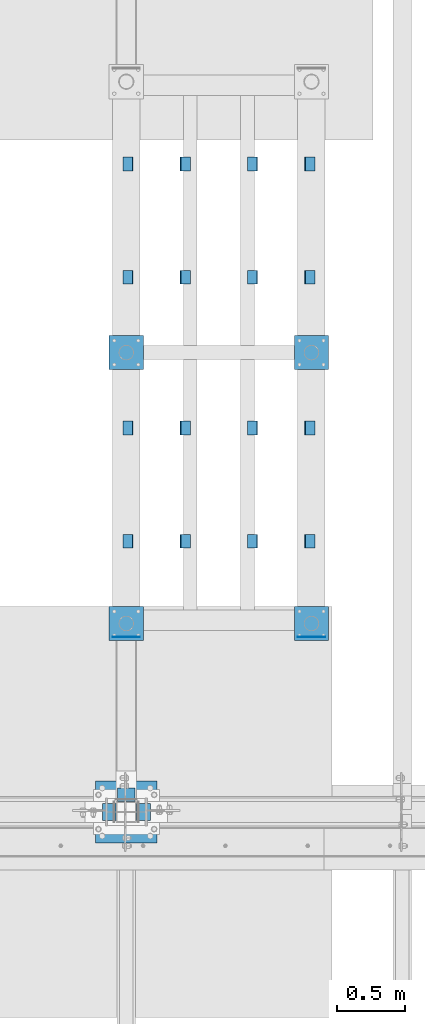
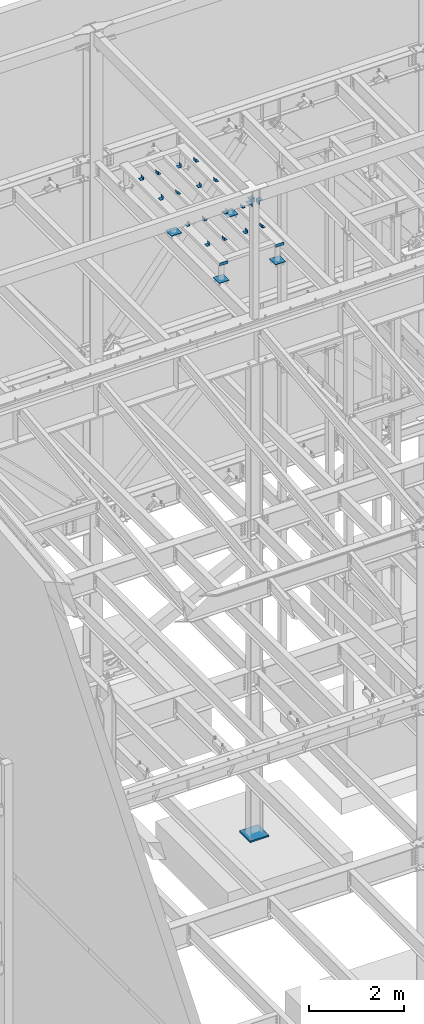
# One storey, part 880 of 1179: 26 beams, 3 elements without a shape of their own.
"""IFC2X3 building model written with IfcOpenShell, lengths in millimetres."""

from ifc_helpers import new_model, si_unit, frame, origin_with_axes, place, context, subcontext, project, spatial, faceted_brep, material, type_object, element, aggregate, save


model = new_model("IFC2X3")

# Units and contexts
model_context = context("Model", 3, precision=1e-05, world=origin_with_axes())
body_context = subcontext(model_context, "Body", "Model", "MODEL_VIEW")
ifc_project = project(units=[si_unit("LENGTHUNIT", "METRE", prefix="MILLI"), si_unit("AREAUNIT", "SQUARE_METRE"), si_unit("VOLUMEUNIT", "CUBIC_METRE"), si_unit("MASSUNIT", "GRAM", prefix="KILO"), si_unit("TIMEUNIT", "SECOND"), si_unit("PLANEANGLEUNIT", "RADIAN"), si_unit("SOLIDANGLEUNIT", "STERADIAN"), si_unit("THERMODYNAMICTEMPERATUREUNIT", "DEGREE_CELSIUS"), si_unit("LUMINOUSINTENSITYUNIT", "LUMEN")], contexts=[model_context])

# Site, building, storey
site_placement = place(None, origin_with_axes())
site = spatial("IfcSite", under=ifc_project, at=site_placement, CompositionType="ELEMENT")
building_placement = place(site_placement, origin_with_axes())
building = spatial("IfcBuilding", under=site, at=building_placement, Name="Undefined", CompositionType="ELEMENT")
storey_placement = place(building_placement, origin_with_axes())
storey = spatial("IfcBuildingStorey", under=building, at=storey_placement, Name="Undefined", CompositionType="ELEMENT", Elevation=0.0)

# Assembly, beams
assembly_1_placement = place(storey_placement, origin_with_axes())
assembly_1 = element("IfcElementAssembly", 1, at=assembly_1_placement, inside=storey, Name="FRAME", AssemblyPlace="NOTDEFINED", PredefinedType="RIGID_FRAME")
ifc_material_1 = material(Name="STEEL/A36")
beam_type_1 = type_object("IfcBeamType", Name="L3X3X1/4", PredefinedType="NOTDEFINED")
beam_1_placement = place(assembly_1_placement, frame((8716.43333333333, 39140.7344873485, 13798.55), z_axis=(0.0, 0.0, 1.0), x_axis=(0.0, 1.0, 0.0)))
beam_1 = element("IfcBeam", 2, at=beam_1_placement, type_object=beam_type_1, material=ifc_material_1, Name="ANGLE", ObjectType="L3X3X1/4", context=body_context, shape_type="Brep", body=[
    faceted_brep([(0.0, 38.0999999999985, -38.0999999999999), (0.0, 38.0999999999985, 38.0999999999999), (101.600000000035, 38.0999999999985, 38.099999999994), (101.599999999962, 38.0999999999985, -38.1000000000058), (0.0, 31.75, 38.1000000000004), (101.600000000035, 31.75, 38.099999999994), (0.0, 31.75, -31.75), (101.599999999969, 31.75, -31.7500000000064), (0.0, -38.0999999999985, -31.75), (101.599999999969, -38.0999999999985, -31.7500000000064), (0.0, -38.0999999999985, -38.0999999999999), (101.599999999962, -38.0999999999985, -38.1000000000058)], [[[0, 1, 2, 3]], [[1, 4, 5, 2]], [[4, 6, 7, 5]], [[6, 8, 9, 7]], [[8, 10, 11, 9]], [[10, 0, 3, 11]], [[5, 7, 9, 11, 3, 2]], [[10, 8, 6, 4, 1, 0]]]),
])
beam_2_placement = place(assembly_1_placement, frame((9639.3, 39140.7344873485, 13798.55), z_axis=(0.0, 0.0, 1.0), x_axis=(0.0, 1.0, 0.0)))
beam_2 = element("IfcBeam", 3, at=beam_2_placement, type_object=beam_type_1, material=ifc_material_1, Name="ANGLE", ObjectType="L3X3X1/4", context=body_context, shape_type="Brep", body=[
    faceted_brep([(0.0, 38.0999999999985, -38.0999999999999), (0.0, 38.0999999999985, 38.0999999999999), (101.600000000035, 38.0999999999985, 38.099999999994), (101.599999999962, 38.0999999999985, -38.1000000000058), (0.0, 31.75, 38.1000000000004), (101.600000000035, 31.75, 38.099999999994), (0.0, 31.75, -31.75), (101.599999999969, 31.75, -31.7500000000064), (0.0, -38.0999999999985, -31.75), (101.599999999969, -38.0999999999985, -31.7500000000064), (0.0, -38.0999999999985, -38.0999999999999), (101.599999999962, -38.0999999999985, -38.1000000000058)], [[[0, 1, 2, 3]], [[1, 4, 5, 2]], [[4, 6, 7, 5]], [[6, 8, 9, 7]], [[8, 10, 11, 9]], [[10, 0, 3, 11]], [[5, 7, 9, 11, 3, 2]], [[10, 8, 6, 4, 1, 0]]]),
])
beam_3_placement = place(assembly_1_placement, frame((9215.96666666667, 39140.7344873485, 13798.55), z_axis=(-1.0, 0.0, 0.0), x_axis=(0.0, 1.0, 0.0)))
beam_3 = element("IfcBeam", 4, at=beam_3_placement, type_object=beam_type_1, material=ifc_material_1, Name="ANGLE", ObjectType="L3X3X1/4", context=body_context, shape_type="Brep", body=[
    faceted_brep([(0.0, 38.0999999999985, -38.0999999999999), (0.0, 38.0999999999985, 38.0999999999999), (101.600000000035, 38.0999999999985, 38.099999999994), (101.599999999962, 38.0999999999985, -38.1000000000058), (0.0, 31.75, 38.1000000000004), (101.600000000035, 31.75, 38.099999999994), (0.0, 31.75, -31.75), (101.599999999969, 31.75, -31.7500000000064), (0.0, -38.0999999999985, -31.75), (101.599999999969, -38.0999999999985, -31.7500000000064), (0.0, -38.0999999999985, -38.0999999999999), (101.599999999962, -38.0999999999985, -38.1000000000058)], [[[0, 1, 2, 3]], [[1, 4, 5, 2]], [[4, 6, 7, 5]], [[6, 8, 9, 7]], [[8, 10, 11, 9]], [[10, 0, 3, 11]], [[5, 7, 9, 11, 3, 2]], [[10, 8, 6, 4, 1, 0]]]),
])
beam_4_placement = place(assembly_1_placement, frame((8293.01264129884, 39140.7344873485, 13798.55), z_axis=(-1.0, 0.0, 0.0), x_axis=(0.0, 1.0, 0.0)))
beam_4 = element("IfcBeam", 5, at=beam_4_placement, type_object=beam_type_1, material=ifc_material_1, Name="ANGLE", ObjectType="L3X3X1/4", context=body_context, shape_type="Brep", body=[
    faceted_brep([(0.0, 38.0999999999985, -38.0999999999999), (0.0, 38.0999999999985, 38.0999999999999), (101.600000000035, 38.0999999999985, 38.099999999994), (101.599999999962, 38.0999999999985, -38.1000000000058), (0.0, 31.75, 38.1000000000004), (101.600000000035, 31.75, 38.099999999994), (0.0, 31.75, -31.75), (101.599999999969, 31.75, -31.7500000000064), (0.0, -38.0999999999985, -31.75), (101.599999999969, -38.0999999999985, -31.7500000000064), (0.0, -38.0999999999985, -38.0999999999999), (101.599999999962, -38.0999999999985, -38.1000000000058)], [[[0, 1, 2, 3]], [[1, 4, 5, 2]], [[4, 6, 7, 5]], [[6, 8, 9, 7]], [[8, 10, 11, 9]], [[10, 0, 3, 11]], [[5, 7, 9, 11, 3, 2]], [[10, 8, 6, 4, 1, 0]]]),
])
beam_5_placement = place(assembly_1_placement, frame((8716.43333333333, 38302.5344873485, 13798.55), z_axis=(0.0, 0.0, 1.0), x_axis=(0.0, 1.0, 0.0)))
beam_5 = element("IfcBeam", 6, at=beam_5_placement, type_object=beam_type_1, material=ifc_material_1, Name="ANGLE", ObjectType="L3X3X1/4", context=body_context, shape_type="Brep", body=[
    faceted_brep([(0.0, 38.0999999999985, -38.0999999999999), (0.0, 38.0999999999985, 38.0999999999999), (101.600000000035, 38.0999999999985, 38.099999999994), (101.599999999962, 38.0999999999985, -38.1000000000058), (0.0, 31.75, 38.1000000000004), (101.600000000035, 31.75, 38.099999999994), (0.0, 31.75, -31.75), (101.599999999969, 31.75, -31.7500000000064), (0.0, -38.0999999999985, -31.75), (101.599999999969, -38.0999999999985, -31.7500000000064), (0.0, -38.0999999999985, -38.0999999999999), (101.599999999962, -38.0999999999985, -38.1000000000058)], [[[0, 1, 2, 3]], [[1, 4, 5, 2]], [[4, 6, 7, 5]], [[6, 8, 9, 7]], [[8, 10, 11, 9]], [[10, 0, 3, 11]], [[5, 7, 9, 11, 3, 2]], [[10, 8, 6, 4, 1, 0]]]),
])
beam_6_placement = place(assembly_1_placement, frame((9639.3, 38302.5344873485, 13798.55), z_axis=(0.0, 0.0, 1.0), x_axis=(0.0, 1.0, 0.0)))
beam_6 = element("IfcBeam", 7, at=beam_6_placement, type_object=beam_type_1, material=ifc_material_1, Name="ANGLE", ObjectType="L3X3X1/4", context=body_context, shape_type="Brep", body=[
    faceted_brep([(0.0, 38.0999999999985, -38.0999999999999), (0.0, 38.0999999999985, 38.0999999999999), (101.600000000035, 38.0999999999985, 38.099999999994), (101.599999999962, 38.0999999999985, -38.1000000000058), (0.0, 31.75, 38.1000000000004), (101.600000000035, 31.75, 38.099999999994), (0.0, 31.75, -31.75), (101.599999999969, 31.75, -31.7500000000064), (0.0, -38.0999999999985, -31.75), (101.599999999969, -38.0999999999985, -31.7500000000064), (0.0, -38.0999999999985, -38.0999999999999), (101.599999999962, -38.0999999999985, -38.1000000000058)], [[[0, 1, 2, 3]], [[1, 4, 5, 2]], [[4, 6, 7, 5]], [[6, 8, 9, 7]], [[8, 10, 11, 9]], [[10, 0, 3, 11]], [[5, 7, 9, 11, 3, 2]], [[10, 8, 6, 4, 1, 0]]]),
])
beam_7_placement = place(assembly_1_placement, frame((9215.96666666667, 38302.5344873485, 13798.55), z_axis=(-1.0, 0.0, 0.0), x_axis=(0.0, 1.0, 0.0)))
beam_7 = element("IfcBeam", 8, at=beam_7_placement, type_object=beam_type_1, material=ifc_material_1, Name="ANGLE", ObjectType="L3X3X1/4", context=body_context, shape_type="Brep", body=[
    faceted_brep([(0.0, 38.0999999999985, -38.0999999999999), (0.0, 38.0999999999985, 38.0999999999999), (101.600000000035, 38.0999999999985, 38.099999999994), (101.599999999962, 38.0999999999985, -38.1000000000058), (0.0, 31.75, 38.1000000000004), (101.600000000035, 31.75, 38.099999999994), (0.0, 31.75, -31.75), (101.599999999969, 31.75, -31.7500000000064), (0.0, -38.0999999999985, -31.75), (101.599999999969, -38.0999999999985, -31.7500000000064), (0.0, -38.0999999999985, -38.0999999999999), (101.599999999962, -38.0999999999985, -38.1000000000058)], [[[0, 1, 2, 3]], [[1, 4, 5, 2]], [[4, 6, 7, 5]], [[6, 8, 9, 7]], [[8, 10, 11, 9]], [[10, 0, 3, 11]], [[5, 7, 9, 11, 3, 2]], [[10, 8, 6, 4, 1, 0]]]),
])
beam_8_placement = place(assembly_1_placement, frame((8293.01264129884, 38302.5344873485, 13798.55), z_axis=(-1.0, 0.0, 0.0), x_axis=(0.0, 1.0, 0.0)))
beam_8 = element("IfcBeam", 9, at=beam_8_placement, type_object=beam_type_1, material=ifc_material_1, Name="ANGLE", ObjectType="L3X3X1/4", context=body_context, shape_type="Brep", body=[
    faceted_brep([(0.0, 38.0999999999985, -38.0999999999999), (0.0, 38.0999999999985, 38.0999999999999), (101.600000000035, 38.0999999999985, 38.099999999994), (101.599999999962, 38.0999999999985, -38.1000000000058), (0.0, 31.75, 38.1000000000004), (101.600000000035, 31.75, 38.099999999994), (0.0, 31.75, -31.75), (101.599999999969, 31.75, -31.7500000000064), (0.0, -38.0999999999985, -31.75), (101.599999999969, -38.0999999999985, -31.7500000000064), (0.0, -38.0999999999985, -38.0999999999999), (101.599999999962, -38.0999999999985, -38.1000000000058)], [[[0, 1, 2, 3]], [[1, 4, 5, 2]], [[4, 6, 7, 5]], [[6, 8, 9, 7]], [[8, 10, 11, 9]], [[10, 0, 3, 11]], [[5, 7, 9, 11, 3, 2]], [[10, 8, 6, 4, 1, 0]]]),
])
beam_9_placement = place(assembly_1_placement, frame((8716.43333333333, 37184.9344873485, 13798.55), z_axis=(0.0, 0.0, 1.0), x_axis=(0.0, 1.0, 0.0)))
beam_9 = element("IfcBeam", 10, at=beam_9_placement, type_object=beam_type_1, material=ifc_material_1, Name="ANGLE", ObjectType="L3X3X1/4", context=body_context, shape_type="Brep", body=[
    faceted_brep([(0.0, 38.0999999999985, -38.0999999999999), (0.0, 38.0999999999985, 38.0999999999999), (101.600000000035, 38.0999999999985, 38.099999999994), (101.599999999962, 38.0999999999985, -38.1000000000058), (0.0, 31.75, 38.1000000000004), (101.600000000035, 31.75, 38.099999999994), (0.0, 31.75, -31.75), (101.599999999969, 31.75, -31.7500000000064), (0.0, -38.0999999999985, -31.75), (101.599999999969, -38.0999999999985, -31.7500000000064), (0.0, -38.0999999999985, -38.0999999999999), (101.599999999962, -38.0999999999985, -38.1000000000058)], [[[0, 1, 2, 3]], [[1, 4, 5, 2]], [[4, 6, 7, 5]], [[6, 8, 9, 7]], [[8, 10, 11, 9]], [[10, 0, 3, 11]], [[5, 7, 9, 11, 3, 2]], [[10, 8, 6, 4, 1, 0]]]),
])
beam_10_placement = place(assembly_1_placement, frame((9639.3, 37184.9344873485, 13798.55), z_axis=(0.0, 0.0, 1.0), x_axis=(0.0, 1.0, 0.0)))
beam_10 = element("IfcBeam", 11, at=beam_10_placement, type_object=beam_type_1, material=ifc_material_1, Name="ANGLE", ObjectType="L3X3X1/4", context=body_context, shape_type="Brep", body=[
    faceted_brep([(0.0, 38.0999999999985, -38.0999999999999), (0.0, 38.0999999999985, 38.0999999999999), (101.600000000035, 38.0999999999985, 38.099999999994), (101.599999999962, 38.0999999999985, -38.1000000000058), (0.0, 31.75, 38.1000000000004), (101.600000000035, 31.75, 38.099999999994), (0.0, 31.75, -31.75), (101.599999999969, 31.75, -31.7500000000064), (0.0, -38.0999999999985, -31.75), (101.599999999969, -38.0999999999985, -31.7500000000064), (0.0, -38.0999999999985, -38.0999999999999), (101.599999999962, -38.0999999999985, -38.1000000000058)], [[[0, 1, 2, 3]], [[1, 4, 5, 2]], [[4, 6, 7, 5]], [[6, 8, 9, 7]], [[8, 10, 11, 9]], [[10, 0, 3, 11]], [[5, 7, 9, 11, 3, 2]], [[10, 8, 6, 4, 1, 0]]]),
])
beam_11_placement = place(assembly_1_placement, frame((9215.96666666667, 37184.9344873485, 13798.55), z_axis=(-1.0, 0.0, 0.0), x_axis=(0.0, 1.0, 0.0)))
beam_11 = element("IfcBeam", 12, at=beam_11_placement, type_object=beam_type_1, material=ifc_material_1, Name="ANGLE", ObjectType="L3X3X1/4", context=body_context, shape_type="Brep", body=[
    faceted_brep([(0.0, 38.0999999999985, -38.0999999999999), (0.0, 38.0999999999985, 38.0999999999999), (101.600000000035, 38.0999999999985, 38.099999999994), (101.599999999962, 38.0999999999985, -38.1000000000058), (0.0, 31.75, 38.1000000000004), (101.600000000035, 31.75, 38.099999999994), (0.0, 31.75, -31.75), (101.599999999969, 31.75, -31.7500000000064), (0.0, -38.0999999999985, -31.75), (101.599999999969, -38.0999999999985, -31.7500000000064), (0.0, -38.0999999999985, -38.0999999999999), (101.599999999962, -38.0999999999985, -38.1000000000058)], [[[0, 1, 2, 3]], [[1, 4, 5, 2]], [[4, 6, 7, 5]], [[6, 8, 9, 7]], [[8, 10, 11, 9]], [[10, 0, 3, 11]], [[5, 7, 9, 11, 3, 2]], [[10, 8, 6, 4, 1, 0]]]),
])
beam_12_placement = place(assembly_1_placement, frame((8293.01264129884, 37184.9344873485, 13798.55), z_axis=(-1.0, 0.0, 0.0), x_axis=(0.0, 1.0, 0.0)))
beam_12 = element("IfcBeam", 13, at=beam_12_placement, type_object=beam_type_1, material=ifc_material_1, Name="ANGLE", ObjectType="L3X3X1/4", context=body_context, shape_type="Brep", body=[
    faceted_brep([(0.0, 38.0999999999985, -38.0999999999999), (0.0, 38.0999999999985, 38.0999999999999), (101.600000000035, 38.0999999999985, 38.099999999994), (101.599999999962, 38.0999999999985, -38.1000000000058), (0.0, 31.75, 38.1000000000004), (101.600000000035, 31.75, 38.099999999994), (0.0, 31.75, -31.75), (101.599999999969, 31.75, -31.7500000000064), (0.0, -38.0999999999985, -31.75), (101.599999999969, -38.0999999999985, -31.7500000000064), (0.0, -38.0999999999985, -38.0999999999999), (101.599999999962, -38.0999999999985, -38.1000000000058)], [[[0, 1, 2, 3]], [[1, 4, 5, 2]], [[4, 6, 7, 5]], [[6, 8, 9, 7]], [[8, 10, 11, 9]], [[10, 0, 3, 11]], [[5, 7, 9, 11, 3, 2]], [[10, 8, 6, 4, 1, 0]]]),
])
beam_13_placement = place(assembly_1_placement, frame((8716.43333333333, 36346.7344873485, 13798.55), z_axis=(0.0, 0.0, 1.0), x_axis=(0.0, 1.0, 0.0)))
beam_13 = element("IfcBeam", 14, at=beam_13_placement, type_object=beam_type_1, material=ifc_material_1, Name="ANGLE", ObjectType="L3X3X1/4", context=body_context, shape_type="Brep", body=[
    faceted_brep([(0.0, 38.0999999999985, -38.0999999999999), (0.0, 38.0999999999985, 38.0999999999999), (101.600000000035, 38.0999999999985, 38.099999999994), (101.599999999962, 38.0999999999985, -38.1000000000058), (0.0, 31.75, 38.1000000000004), (101.600000000035, 31.75, 38.099999999994), (0.0, 31.75, -31.75), (101.599999999969, 31.75, -31.7500000000064), (0.0, -38.0999999999985, -31.75), (101.599999999969, -38.0999999999985, -31.7500000000064), (0.0, -38.0999999999985, -38.0999999999999), (101.599999999962, -38.0999999999985, -38.1000000000058)], [[[0, 1, 2, 3]], [[1, 4, 5, 2]], [[4, 6, 7, 5]], [[6, 8, 9, 7]], [[8, 10, 11, 9]], [[10, 0, 3, 11]], [[5, 7, 9, 11, 3, 2]], [[10, 8, 6, 4, 1, 0]]]),
])
beam_14_placement = place(assembly_1_placement, frame((9639.3, 36346.7344873485, 13798.55), z_axis=(0.0, 0.0, 1.0), x_axis=(0.0, 1.0, 0.0)))
beam_14 = element("IfcBeam", 15, at=beam_14_placement, type_object=beam_type_1, material=ifc_material_1, Name="ANGLE", ObjectType="L3X3X1/4", context=body_context, shape_type="Brep", body=[
    faceted_brep([(0.0, 38.0999999999985, -38.0999999999999), (0.0, 38.0999999999985, 38.0999999999999), (101.600000000035, 38.0999999999985, 38.099999999994), (101.599999999962, 38.0999999999985, -38.1000000000058), (0.0, 31.75, 38.1000000000004), (101.600000000035, 31.75, 38.099999999994), (0.0, 31.75, -31.75), (101.599999999969, 31.75, -31.7500000000064), (0.0, -38.0999999999985, -31.75), (101.599999999969, -38.0999999999985, -31.7500000000064), (0.0, -38.0999999999985, -38.0999999999999), (101.599999999962, -38.0999999999985, -38.1000000000058)], [[[0, 1, 2, 3]], [[1, 4, 5, 2]], [[4, 6, 7, 5]], [[6, 8, 9, 7]], [[8, 10, 11, 9]], [[10, 0, 3, 11]], [[5, 7, 9, 11, 3, 2]], [[10, 8, 6, 4, 1, 0]]]),
])
beam_15_placement = place(assembly_1_placement, frame((9215.96666666667, 36346.7344873485, 13798.55), z_axis=(-1.0, 0.0, 0.0), x_axis=(0.0, 1.0, 0.0)))
beam_15 = element("IfcBeam", 16, at=beam_15_placement, type_object=beam_type_1, material=ifc_material_1, Name="ANGLE", ObjectType="L3X3X1/4", context=body_context, shape_type="Brep", body=[
    faceted_brep([(0.0, 38.0999999999985, -38.0999999999999), (0.0, 38.0999999999985, 38.0999999999999), (101.600000000035, 38.0999999999985, 38.099999999994), (101.599999999962, 38.0999999999985, -38.1000000000058), (0.0, 31.75, 38.1000000000004), (101.600000000035, 31.75, 38.099999999994), (0.0, 31.75, -31.75), (101.599999999969, 31.75, -31.7500000000064), (0.0, -38.0999999999985, -31.75), (101.599999999969, -38.0999999999985, -31.7500000000064), (0.0, -38.0999999999985, -38.0999999999999), (101.599999999962, -38.0999999999985, -38.1000000000058)], [[[0, 1, 2, 3]], [[1, 4, 5, 2]], [[4, 6, 7, 5]], [[6, 8, 9, 7]], [[8, 10, 11, 9]], [[10, 0, 3, 11]], [[5, 7, 9, 11, 3, 2]], [[10, 8, 6, 4, 1, 0]]]),
])
beam_16_placement = place(assembly_1_placement, frame((8293.01264129884, 36346.7344873485, 13798.55), z_axis=(-1.0, 0.0, 0.0), x_axis=(0.0, 1.0, 0.0)))
beam_16 = element("IfcBeam", 17, at=beam_16_placement, type_object=beam_type_1, material=ifc_material_1, Name="ANGLE", ObjectType="L3X3X1/4", context=body_context, shape_type="Brep", body=[
    faceted_brep([(0.0, 38.0999999999985, -38.0999999999999), (0.0, 38.0999999999985, 38.0999999999999), (101.600000000035, 38.0999999999985, 38.099999999994), (101.599999999962, 38.0999999999985, -38.1000000000058), (0.0, 31.75, 38.1000000000004), (101.600000000035, 31.75, 38.099999999994), (0.0, 31.75, -31.75), (101.599999999969, 31.75, -31.7500000000064), (0.0, -38.0999999999985, -31.75), (101.599999999969, -38.0999999999985, -31.7500000000064), (0.0, -38.0999999999985, -38.0999999999999), (101.599999999962, -38.0999999999985, -38.1000000000058)], [[[0, 1, 2, 3]], [[1, 4, 5, 2]], [[4, 6, 7, 5]], [[6, 8, 9, 7]], [[8, 10, 11, 9]], [[10, 0, 3, 11]], [[5, 7, 9, 11, 3, 2]], [[10, 8, 6, 4, 1, 0]]]),
])
beam_type_2 = type_object("IfcBeamType", PredefinedType="NOTDEFINED")
beam_17_placement = place(assembly_1_placement, frame((8178.8, 35688.7154873485, 13722.35), z_axis=(0.0, 0.0, -1.0), x_axis=(1.0, 0.0, 0.0)))
beam_17 = element("IfcBeam", 18, at=beam_17_placement, type_object=beam_type_2, material=ifc_material_1, Name="PLATE", context=body_context, shape_type="Brep", body=[
    faceted_brep([(0.0, 2.38149999999951, -38.0999999999985), (0.0, 2.38149999999951, 38.0999999999985), (203.199999999997, 2.38150000000314, 38.1000000000004), (203.199999999997, 2.38150000000314, -38.1000000000004), (0.0, -2.38149999999951, 38.0999999999985), (203.199999999997, -2.38150000000314, 38.1000000000004), (0.0, -2.38149999999951, -38.0999999999985), (203.199999999997, -2.38150000000314, -38.1000000000004)], [[[0, 1, 2, 3]], [[1, 4, 5, 2]], [[4, 6, 7, 5]], [[6, 0, 3, 7]], [[5, 7, 3, 2]], [[6, 4, 1, 0]]]),
])
beam_18_placement = place(assembly_1_placement, frame((9550.4, 35688.7154873485, 13722.35), z_axis=(0.0, 0.0, -1.0), x_axis=(1.0, 0.0, 0.0)))
beam_18 = element("IfcBeam", 19, at=beam_18_placement, type_object=beam_type_2, material=ifc_material_1, Name="PLATE", context=body_context, shape_type="Brep", body=[
    faceted_brep([(0.0, 2.38149999999951, -38.0999999999985), (0.0, 2.38149999999951, 38.0999999999985), (203.199999999997, 2.38150000000314, 38.1000000000004), (203.199999999997, 2.38150000000314, -38.1000000000004), (0.0, -2.38149999999951, 38.0999999999985), (203.199999999997, -2.38150000000314, 38.1000000000004), (0.0, -2.38149999999951, -38.0999999999985), (203.199999999997, -2.38150000000314, -38.1000000000004)], [[[0, 1, 2, 3]], [[1, 4, 5, 2]], [[4, 6, 7, 5]], [[6, 0, 3, 7]], [[5, 7, 3, 2]], [[6, 4, 1, 0]]]),
])

assembly_2_placement = place(storey_placement, origin_with_axes())
assembly_2 = element("IfcElementAssembly", 20, at=assembly_2_placement, inside=storey, Name="COLUMN", AssemblyPlace="NOTDEFINED", PredefinedType="RIGID_FRAME")
beam_type_3 = type_object("IfcBeamType", Name="L4X4X3/8", PredefinedType="NOTDEFINED")
beam_19_placement = place(assembly_2_placement, frame((8343.9, 34518.6, 16071.85), z_axis=(0.0, 1.0, 0.0), x_axis=(-1.0, 0.0, 0.0)))
beam_19 = element("IfcBeam", 21, at=beam_19_placement, type_object=beam_type_3, material=ifc_material_1, Name="ANGLE", ObjectType="L4X4X3/8", context=body_context, shape_type="Brep", body=[
    faceted_brep([(1.90993887372315e-11, 50.8000000000002, -50.8000000000002), (1.90993887372315e-11, 50.8000000000002, 50.8000000000002), (126.999999999993, 50.8000000000002, 50.7999999999993), (126.999999999993, 50.8000000000002, -50.7999999999993), (0.0, 41.2750000000015, 50.8000000000029), (126.999999999993, 41.2749999999996, 50.7999999999993), (0.0, 41.2750000000015, -41.2750000000015), (126.999999999993, 41.2749999999996, -41.2749999999996), (0.0, -50.7999999999993, -41.2750000000015), (126.999999999993, -50.8000000000002, -41.2749999999996), (-1.81898940354586e-11, -50.7999999999997, -50.8000000000002), (126.999999999993, -50.8000000000002, -50.7999999999993)], [[[0, 1, 2, 3]], [[1, 4, 5, 2]], [[4, 6, 7, 5]], [[6, 8, 9, 7]], [[8, 10, 11, 9]], [[10, 0, 3, 11]], [[5, 7, 9, 11, 3, 2]], [[10, 8, 6, 4, 1, 0]]]),
])
beam_20_placement = place(assembly_2_placement, frame((8153.4, 34328.1, 16071.85), z_axis=(0.0, 0.0, -1.0), x_axis=(0.0, 1.0, 0.0)))
beam_20 = element("IfcBeam", 22, at=beam_20_placement, type_object=beam_type_3, material=ifc_material_1, Name="ANGLE", ObjectType="L4X4X3/8", context=body_context, shape_type="Brep", body=[
    faceted_brep([(1.90993887372315e-11, 50.8000000000002, -50.8000000000002), (1.90993887372315e-11, 50.8000000000002, 50.8000000000002), (126.999999999993, 50.8000000000002, 50.7999999999993), (126.999999999993, 50.8000000000002, -50.7999999999993), (0.0, 41.2750000000015, 50.8000000000029), (126.999999999993, 41.2749999999996, 50.7999999999993), (0.0, 41.2750000000015, -41.2750000000015), (126.999999999993, 41.2749999999996, -41.2749999999996), (0.0, -50.7999999999993, -41.2750000000015), (126.999999999993, -50.8000000000002, -41.2749999999996), (-1.81898940354586e-11, -50.7999999999997, -50.8000000000002), (126.999999999993, -50.8000000000002, -50.7999999999993)], [[[0, 1, 2, 3]], [[1, 4, 5, 2]], [[4, 6, 7, 5]], [[6, 8, 9, 7]], [[8, 10, 11, 9]], [[10, 0, 3, 11]], [[5, 7, 9, 11, 3, 2]], [[10, 8, 6, 4, 1, 0]]]),
])
beam_21_placement = place(assembly_2_placement, frame((8407.4, 34328.1, 16071.85), z_axis=(1.0, 0.0, 0.0), x_axis=(0.0, 1.0, 0.0)))
beam_21 = element("IfcBeam", 23, at=beam_21_placement, type_object=beam_type_3, material=ifc_material_1, Name="ANGLE", ObjectType="L4X4X3/8", context=body_context, shape_type="Brep", body=[
    faceted_brep([(1.90993887372315e-11, 50.8000000000002, -50.8000000000002), (1.90993887372315e-11, 50.8000000000002, 50.8000000000002), (126.999999999993, 50.8000000000002, 50.7999999999993), (126.999999999993, 50.8000000000002, -50.7999999999993), (0.0, 41.2750000000015, 50.8000000000029), (126.999999999993, 41.2749999999996, 50.7999999999993), (0.0, 41.2750000000015, -41.2750000000015), (126.999999999993, 41.2749999999996, -41.2749999999996), (0.0, -50.7999999999993, -41.2750000000015), (126.999999999993, -50.8000000000002, -41.2749999999996), (-1.81898940354586e-11, -50.7999999999997, -50.8000000000002), (126.999999999993, -50.8000000000002, -50.7999999999993)], [[[0, 1, 2, 3]], [[1, 4, 5, 2]], [[4, 6, 7, 5]], [[6, 8, 9, 7]], [[8, 10, 11, 9]], [[10, 0, 3, 11]], [[5, 7, 9, 11, 3, 2]], [[10, 8, 6, 4, 1, 0]]]),
])
aggregate(assembly_2, [beam_19, beam_20, beam_21])

# Beam
beam_type_4 = type_object("IfcBeamType", PredefinedType="NOTDEFINED")
beam_22_placement = place(assembly_1_placement, frame((9652.0, 37667.5344873485, 13258.8), z_axis=(1.0, 0.0, 0.0), x_axis=(0.0, 1.0, 0.0)))
beam_22 = element("IfcBeam", 24, at=beam_22_placement, type_object=beam_type_4, material=ifc_material_1, Name="PLATE", context=body_context, shape_type="Brep", body=[
    faceted_brep([(0.0, 6.35000000000036, -127.0), (0.0, 6.34999999999854, 127.0), (254.0, 6.35000000000036, 127.0), (254.0, 6.35000000000036, -127.0), (0.0, -6.34999999999854, 127.0), (254.0, -6.35000000000036, 127.0), (0.0, -6.35000000000036, -127.0), (254.0, -6.35000000000036, -127.0)], [[[0, 1, 2, 3]], [[1, 4, 5, 2]], [[4, 6, 7, 5]], [[6, 0, 3, 7]], [[5, 7, 3, 2]], [[6, 4, 1, 0]]]),
])

beam_23_placement = place(assembly_1_placement, frame((8280.4, 37667.5344873485, 13258.8), z_axis=(1.0, 0.0, 0.0), x_axis=(0.0, 1.0, 0.0)))
beam_23 = element("IfcBeam", 25, at=beam_23_placement, type_object=beam_type_4, material=ifc_material_1, Name="PLATE", context=body_context, shape_type="Brep", body=[
    faceted_brep([(0.0, 6.35000000000036, -127.0), (0.0, 6.34999999999854, 127.0), (254.0, 6.35000000000036, 127.0), (254.0, 6.35000000000036, -127.0), (0.0, -6.34999999999854, 127.0), (254.0, -6.35000000000036, 127.0), (0.0, -6.35000000000036, -127.0), (254.0, -6.35000000000036, -127.0)], [[[0, 1, 2, 3]], [[1, 4, 5, 2]], [[4, 6, 7, 5]], [[6, 0, 3, 7]], [[5, 7, 3, 2]], [[6, 4, 1, 0]]]),
])

beam_24_placement = place(assembly_1_placement, frame((9652.0, 35660.9344873485, 13258.8), z_axis=(1.0, 0.0, 0.0), x_axis=(0.0, 1.0, 0.0)))
beam_24 = element("IfcBeam", 26, at=beam_24_placement, type_object=beam_type_4, material=ifc_material_1, Name="PLATE", context=body_context, shape_type="Brep", body=[
    faceted_brep([(0.0, 6.35000000000036, -127.0), (0.0, 6.34999999999854, 127.0), (254.0, 6.35000000000036, 127.0), (254.0, 6.35000000000036, -127.0), (0.0, -6.34999999999854, 127.0), (254.0, -6.35000000000036, 127.0), (0.0, -6.35000000000036, -127.0), (254.0, -6.35000000000036, -127.0)], [[[0, 1, 2, 3]], [[1, 4, 5, 2]], [[4, 6, 7, 5]], [[6, 0, 3, 7]], [[5, 7, 3, 2]], [[6, 4, 1, 0]]]),
])

beam_25_placement = place(assembly_1_placement, frame((8280.4, 35660.9344873485, 13258.8), z_axis=(1.0, 0.0, 0.0), x_axis=(0.0, 1.0, 0.0)))
beam_25 = element("IfcBeam", 27, at=beam_25_placement, type_object=beam_type_4, material=ifc_material_1, Name="PLATE", context=body_context, shape_type="Brep", body=[
    faceted_brep([(0.0, 6.35000000000036, -127.0), (0.0, 6.34999999999854, 127.0), (254.0, 6.35000000000036, 127.0), (254.0, 6.35000000000036, -127.0), (0.0, -6.34999999999854, 127.0), (254.0, -6.35000000000036, 127.0), (0.0, -6.35000000000036, -127.0), (254.0, -6.35000000000036, -127.0)], [[[0, 1, 2, 3]], [[1, 4, 5, 2]], [[4, 6, 7, 5]], [[6, 0, 3, 7]], [[5, 7, 3, 2]], [[6, 4, 1, 0]]]),
])

aggregate(assembly_1, [beam_1, beam_2, beam_3, beam_4, beam_5, beam_6, beam_7, beam_8, beam_9, beam_10, beam_11, beam_12, beam_13, beam_14, beam_15, beam_16, beam_17, beam_18, beam_22, beam_23, beam_24, beam_25])

# Assembly, beam
assembly_3_placement = place(storey_placement, origin_with_axes())
assembly_3 = element("IfcElementAssembly", 28, at=assembly_3_placement, inside=storey, Name="COLUMN", AssemblyPlace="NOTDEFINED", PredefinedType="RIGID_FRAME")
ifc_material_2 = material(Name="STEEL/A572-GR.50")
beam_type_5 = type_object("IfcBeamType", PredefinedType="NOTDEFINED")
beam_26_placement = place(assembly_3_placement, frame((8280.4, 34163.0, -184.15), z_axis=(-1.0, 0.0, 0.0), x_axis=(0.0, 1.0, 0.0)))
beam_26 = element("IfcBeam", 29, at=beam_26_placement, type_object=beam_type_5, material=ifc_material_2, context=body_context, shape_type="Brep", body=[
    faceted_brep([(0.0, 19.05, -228.6), (0.0, 19.05, 228.6), (457.199999999997, 19.05, 228.599999999999), (457.199999999997, 19.05, -228.599999999999), (0.0, -19.05, 228.6), (457.199999999997, -19.05, 228.599999999999), (0.0, -19.05, -228.6), (457.199999999997, -19.05, -228.599999999999)], [[[0, 1, 2, 3]], [[1, 4, 5, 2]], [[4, 6, 7, 5]], [[6, 0, 3, 7]], [[5, 7, 3, 2]], [[6, 4, 1, 0]]]),
])
aggregate(assembly_3, [beam_26])

save(model, "model.ifc")
